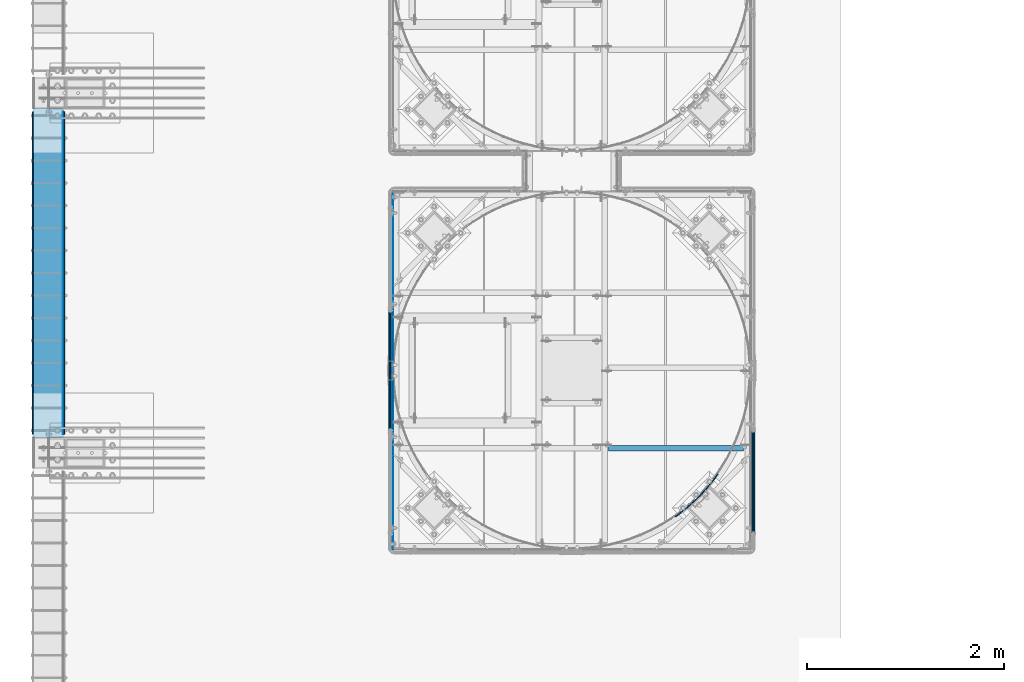
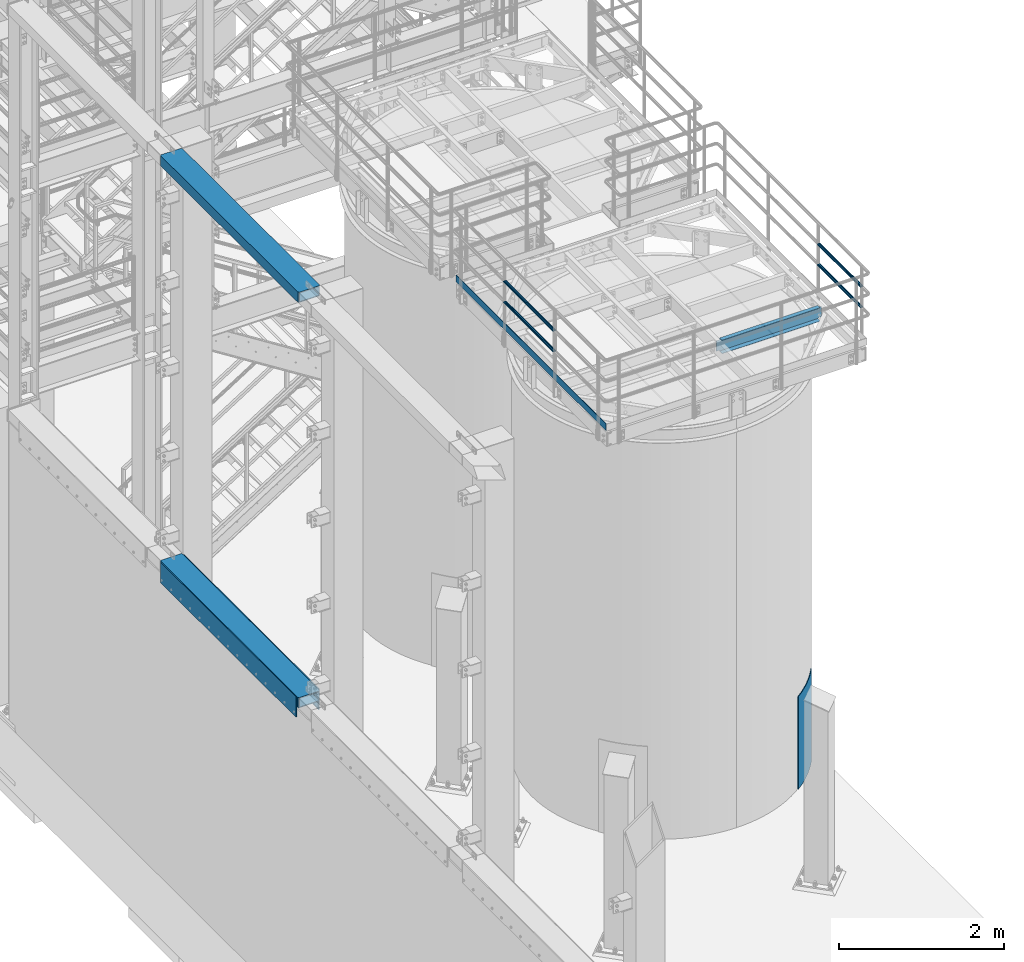
# One storey, part 916 of 1876: 12 beams, 7 elements without a shape of their own.
"""IFC2X3 building model written with IfcOpenShell, lengths in millimetres."""

from ifc_helpers import new_model, si_unit, frame, origin_with_axes, place, context, subcontext, project, spatial, faceted_brep, material, type_object, element, aggregate, save


model = new_model("IFC2X3")

# Units and contexts
model_context = context("Model", 3, precision=1e-05, world=origin_with_axes())
body_context = subcontext(model_context, "Body", "Model", "MODEL_VIEW")
ifc_project = project(units=[si_unit("LENGTHUNIT", "METRE", prefix="MILLI"), si_unit("AREAUNIT", "SQUARE_METRE"), si_unit("VOLUMEUNIT", "CUBIC_METRE"), si_unit("MASSUNIT", "GRAM", prefix="KILO"), si_unit("TIMEUNIT", "SECOND"), si_unit("PLANEANGLEUNIT", "RADIAN"), si_unit("SOLIDANGLEUNIT", "STERADIAN"), si_unit("THERMODYNAMICTEMPERATUREUNIT", "DEGREE_CELSIUS"), si_unit("LUMINOUSINTENSITYUNIT", "LUMEN")], contexts=[model_context])

# Site, building, storey
site_placement = place(None, origin_with_axes())
site = spatial("IfcSite", under=ifc_project, at=site_placement, CompositionType="ELEMENT")
building_placement = place(site_placement, origin_with_axes())
building = spatial("IfcBuilding", under=site, at=building_placement, Name="Undefined", CompositionType="ELEMENT")
storey_placement = place(building_placement, origin_with_axes())
storey = spatial("IfcBuildingStorey", under=building, at=storey_placement, Name="Undefined", CompositionType="ELEMENT", Elevation=0.0)

# Assembly, beam
assembly_1_placement = place(storey_placement, origin_with_axes())
assembly_1 = element("IfcElementAssembly", 1, at=assembly_1_placement, inside=storey, Name="BEAM", AssemblyPlace="NOTDEFINED", PredefinedType="RIGID_FRAME")
ifc_material_1 = material()
beam_type_1 = type_object("IfcBeamType", Name="HSS12X6X1/2", PredefinedType="NOTDEFINED")
beam_1_placement = place(assembly_1_placement, frame((-139.7, -14274.8, 10591.8), z_axis=(-1.0, 0.0, 0.0), x_axis=(0.0, 1.0, 0.0)))
beam_1 = element("IfcBeam", 2, at=beam_1_placement, type_object=beam_type_1, material=ifc_material_1, Name="BEAM", ObjectType="HSS12X6X1/2", context=body_context, shape_type="Brep", body=[
    faceted_brep([(0.0, -63.5, -139.7), (0.0, -76.2000000000007, -139.699999999812), (0.0, -76.2000000000007, 139.700000000026), (0.0, -63.5, 139.7), (0.0, 76.2000000000007, 139.700000000026), (0.0, 63.5, 139.7), (12.6999999999734, -76.2000000000007, 152.4), (12.6999999999734, 76.2000000000007, 152.4), (0.0, 76.2000000000007, -139.699999999812), (0.0, 63.5, -139.7), (12.7000000000025, -76.2000000000007, -152.4), (12.7000000000025, 76.2000000000007, -152.4), (3340.1, 76.2000000000007, -152.4), (3340.1, -76.2000000000007, -152.4), (3352.8, -63.5, -139.7), (3352.8, 63.5, -139.7), (3352.8, 76.2000000000007, -139.7), (3352.8, -76.2000000000007, -139.7), (3352.8, -76.2000000000007, 139.7), (3340.1, -76.2000000000007, 152.4), (3340.1, 76.2000000000007, 152.4), (3352.8, 76.2000000000007, 139.7), (3352.8, 63.5, 139.7), (3352.8, -63.5, 139.7)], [[[0, 1, 2, 3]], [[4, 5, 3, 2, 6, 7]], [[8, 9, 5, 4]], [[10, 11, 12, 13]], [[0, 9, 8, 11, 10, 1]], [[9, 0, 14, 15]], [[12, 16, 15, 14, 17, 13]], [[6, 2, 1, 10, 13, 17, 18, 19]], [[7, 6, 19, 20]], [[16, 12, 11, 8, 4, 7, 20, 21]], [[15, 16, 21, 22]], [[5, 9, 15, 22]], [[3, 5, 22, 23]], [[0, 3, 23, 14]], [[17, 14, 23, 18]], [[22, 21, 20, 19, 18, 23]]]),
])
aggregate(assembly_1, [beam_1])

assembly_2_placement = place(storey_placement, origin_with_axes())
assembly_2 = element("IfcElementAssembly", 3, at=assembly_2_placement, inside=storey, Name="BEAM", AssemblyPlace="NOTDEFINED", PredefinedType="RIGID_FRAME")
beam_2_placement = place(assembly_2_placement, frame((-139.7, -14274.8, 4597.4), z_axis=(-1.0, 0.0, 0.0), x_axis=(0.0, 1.0, 0.0)))
beam_2 = element("IfcBeam", 4, at=beam_2_placement, type_object=beam_type_1, material=ifc_material_1, Name="BEAM", ObjectType="HSS12X6X1/2", context=body_context, shape_type="Brep", body=[
    faceted_brep([(0.0, 63.5, -139.7), (0.0, -63.5, -139.7), (3352.8, -63.5, -139.7), (3352.8, 63.5, -139.7), (3340.10010842724, 76.1999999999998, -152.4), (3340.10010842724, -76.1999999999998, -152.4), (12.6998385541701, -76.2000000000007, -152.4), (12.6998385541701, 76.2000000000007, -152.4), (0.0, 76.2000000000007, -139.699999999812), (0.0, -76.2000000000007, -139.699999999812), (0.0, -76.2000000000007, 139.700000000026), (0.0, -63.5, 139.7), (0.0, 63.5, 139.7), (3352.8, 63.5, 139.7), (3352.8, -63.5, 139.7), (3352.8, -76.2000000000007, -139.7), (3352.8, -76.2000000000007, 139.7), (3352.8, 76.2000000000007, 139.7), (3340.1, 76.2000000000007, 152.4), (3340.1, -76.2000000000007, 152.4), (12.6999999999734, -76.2000000000007, 152.4), (3352.8, 76.2000000000007, -139.7), (0.0, 76.2000000000007, 139.700000000026), (12.6999999999734, 76.2000000000007, 152.4)], [[[0, 1, 2, 3]], [[4, 5, 6, 7]], [[1, 0, 8, 7, 6, 9]], [[1, 9, 10, 11]], [[11, 12, 13, 14]], [[1, 11, 14, 2]], [[15, 2, 14, 16]], [[13, 17, 18, 19, 16, 14]], [[9, 6, 5, 15, 16, 19, 20, 10]], [[4, 21, 3, 2, 15, 5]], [[3, 21, 17, 13]], [[12, 0, 3, 13]], [[8, 0, 12, 22]], [[18, 17, 21, 4, 7, 8, 22, 23]], [[23, 20, 19, 18]], [[22, 12, 11, 10, 20, 23]]]),
])

# Assembly, beams
assembly_3_placement = place(storey_placement, origin_with_axes())
assembly_3 = element("IfcElementAssembly", 5, at=assembly_3_placement, inside=storey, Name="PLATE", AssemblyPlace="NOTDEFINED", PredefinedType="RIGID_FRAME")
ifc_material_2 = material(Name="STEEL/A36")
beam_type_2 = type_object("IfcBeamType", PredefinedType="NOTDEFINED")
beam_3_placement = place(assembly_3_placement, frame((8.73150000000262, -10960.1, 4432.3), z_axis=(0.0, 0.0, 1.0), x_axis=(0.0, -1.0, 0.0)))
beam_3 = element("IfcBeam", 6, at=beam_3_placement, type_object=beam_type_2, material=ifc_material_2, Name="PLATE", context=body_context, shape_type="Brep", body=[
    faceted_brep([(0.0, 3.969, -38.1000000000004), (0.0, 3.969, 38.1000000000004), (3276.6, 3.96900000000096, 38.1000000000004), (3276.6, 3.96900000000096, -38.1000000000004), (0.0, -3.969, 38.1000000000004), (3276.6, -3.96900000000096, 38.1000000000004), (0.0, -3.969, -38.1000000000004), (3276.6, -3.96900000000096, -38.1000000000004)], [[[0, 1, 2, 3]], [[1, 4, 5, 2]], [[4, 6, 7, 5]], [[6, 0, 3, 7]], [[5, 7, 3, 2]], [[6, 4, 1, 0]]]),
])
beam_type_3 = type_object("IfcBeamType", PredefinedType="NOTDEFINED")
beam_4_placement = place(assembly_3_placement, frame((19.0500000000011, -10960.1, 4521.2), z_axis=(0.0, 0.0, 1.0), x_axis=(0.0, -1.0, 0.0)))
beam_4 = element("IfcBeam", 7, at=beam_4_placement, type_object=beam_type_3, material=ifc_material_2, Name="PLATE", context=body_context, shape_type="Brep", body=[
    faceted_brep([(0.0, 6.35000000000002, -152.4), (0.0, 6.35000000000002, 152.4), (3276.6, 6.35000000000002, 152.4), (3276.6, 6.35000000000002, -152.4), (0.0, -6.35000000000002, 152.4), (3276.6, -6.35000000000002, 152.4), (0.0, -6.35000000000002, -152.4), (3276.6, -6.35000000000002, -152.4)], [[[0, 1, 2, 3]], [[1, 4, 5, 2]], [[4, 6, 7, 5]], [[6, 0, 3, 7]], [[5, 7, 3, 2]], [[6, 4, 1, 0]]]),
])
aggregate(assembly_3, [beam_3, beam_4])

# Beam
beam_5_placement = place(assembly_2_placement, frame((-298.449999999997, -10960.1, 4521.2), z_axis=(0.0, 0.0, 1.0), x_axis=(0.0, -1.0, 0.0)))
beam_5 = element("IfcBeam", 8, at=beam_5_placement, type_object=beam_type_3, material=ifc_material_2, Name="PLATE", context=body_context, shape_type="Brep", body=[
    faceted_brep([(0.0, 6.35000000000002, -152.4), (0.0, 6.35000000000002, 152.4), (3276.6, 6.35000000000002, 152.4), (3276.6, 6.35000000000002, -152.4), (0.0, -6.35000000000002, 152.4), (3276.6, -6.35000000000002, 152.4), (0.0, -6.35000000000002, -152.4), (3276.6, -6.35000000000002, -152.4)], [[[0, 1, 2, 3]], [[1, 4, 5, 2]], [[4, 6, 7, 5]], [[6, 0, 3, 7]], [[5, 7, 3, 2]], [[6, 4, 1, 0]]]),
])

aggregate(assembly_2, [beam_5, beam_2])

# Assembly, beams
assembly_4_placement = place(storey_placement, origin_with_axes())
assembly_4 = element("IfcElementAssembly", 9, at=assembly_4_placement, inside=storey, Name="HANDRAIL", AssemblyPlace="NOTDEFINED", PredefinedType="RIGID_FRAME")
ifc_material_3 = material()
beam_type_4 = type_object("IfcBeamType", Name="PIPE1-1/4STD", PredefinedType="NOTDEFINED")
beam_6_placement = place(assembly_4_placement, frame((3338.06943150122, -14198.5644042969, 8480.425), z_axis=(0.0, 0.0, 1.0), x_axis=(0.0, 1.0, 0.0)))
beam_6 = element("IfcBeam", 10, at=beam_6_placement, type_object=beam_type_4, material=ifc_material_3, Name="RAIL", ObjectType="PIPE1-1/4STD", context=body_context, shape_type="Brep", body=[
    faceted_brep([(1200.94245243742, -10.5409999999993, 18.2575475625836), (1200.94245243742, -10.5409999999993, 13.3999612267253), (1200.46603877327, -8.76300000000083, 15.1779612267255), (1198.118, 0.0, 17.5259999999998), (1198.118, 0.0, 21.0820000000003), (1200.46603877327, 8.76300000000083, 15.1779612267255), (1200.94245243742, 10.5409999999993, 13.3999612267253), (1200.94245243742, 10.5409999999993, 18.2575475625836), (1219.2, 21.0820000000003, 0.0), (1208.659, 18.2575475625836, 10.5409999999993), (1208.659, 18.2575475625836, -10.5409999999993), (1205.57941366414, 15.1779612267255, 8.76300000000083), (1207.92745243742, 17.5259999999998, 0.0), (1205.57941366414, 15.1779612267255, -8.76300000000083), (1200.94245243742, 10.5409999999993, -13.3999612267253), (1200.94245243742, 10.5409999999993, -18.2575475625836), (1200.46603877327, 8.76300000000083, -15.1779612267255), (1198.118, 0.0, -17.5259999999998), (1198.118, 0.0, -21.0820000000003), (1200.94245243742, -10.5409999999993, -13.3999612267253), (1200.94245243742, -10.5409999999993, -18.2575475625836), (1200.46603877327, -8.76300000000083, -15.1779612267255), (1219.2, -21.0820000000003, 0.0), (1208.659, -18.2575475625836, -10.5409999999993), (1208.659, -18.2575475625836, 10.5409999999993), (1205.57941366414, -15.1779612267255, -8.76300000000083), (1207.92745243742, -17.5259999999998, 0.0), (1205.57941366414, -15.1779612267255, 8.76300000000083), (10.5409999957128, -18.2575475672238, -10.5409999999993), (18.2575475625817, -10.5410000000011, -18.2575475625836), (9.09494701772928e-13, 21.0820000000003, 0.0), (10.5409999957128, 18.2575475579433, -10.5409999999993), (10.5409999999983, 18.2575475625836, 10.5410000000011), (18.2575475625817, 10.5409999999993, 18.2575475625836), (21.0819999999985, 1.81898940354586e-12, 21.0820000000003), (18.2575475625817, 10.5409999999993, -18.2575475625836), (21.0819999999985, 0.0, -21.0819999999985), (21.0819999999985, 0.0, -17.5259999999998), (18.2575475625817, -10.5409999999974, -13.3999612267271), (18.7339612267233, -8.76300000000083, -15.1779612267255), (18.7339612267251, 8.76299999999901, -15.1779612267255), (18.2575475625817, 10.5410000000011, -13.3999612267235), (13.6205863358573, 15.1779612267255, -8.76299999999901), (11.2725475625839, 17.5259999999998, 0.0), (13.6205863358573, 15.1779612267255, 8.76300000000083), (18.2575475625817, 10.5410000000011, 13.3999612267253), (18.7339612267251, 8.76299999999901, 15.1779612267273), (21.0819999999985, 1.81898940354586e-12, 17.5259999999998), (18.7339612267233, -8.76300000000083, 15.1779612267273), (18.2575475625817, -10.5409999999974, 13.3999612267289), (18.2575475625817, -10.5410000000011, 18.2575475625836), (10.5409999999983, -18.2575475625836, 10.5410000000011), (9.09494701772928e-13, -21.0820000000003, 0.0), (13.6205863358537, -15.1779612267255, 8.76300000000083), (11.2725475625793, -17.5259999999998, 0.0), (13.6205863358537, -15.1779612267255, -8.76299999999901)], [[[0, 1, 2, 3, 4]], [[4, 3, 5, 6, 7]], [[8, 9, 10]], [[7, 6, 11, 12, 13, 14, 15, 10, 9]], [[16, 17, 18, 15, 14]], [[19, 20, 18, 17, 21]], [[22, 23, 24]], [[24, 23, 20, 19, 25, 26, 27, 1, 0]], [[28, 29, 20, 23]], [[30, 31, 32]], [[33, 34, 4, 7]], [[32, 33, 7, 9]], [[30, 32, 9, 8]], [[31, 30, 8, 10]], [[35, 31, 10, 15]], [[36, 35, 15, 18]], [[29, 36, 18, 20]], [[37, 36, 29, 38, 39]], [[40, 41, 35, 36, 37]], [[32, 31, 35, 41, 42, 43, 44, 45, 33]], [[33, 45, 46, 47, 34]], [[34, 47, 48, 49, 50]], [[34, 50, 0, 4]], [[50, 51, 24, 0]], [[51, 52, 22, 24]], [[52, 28, 23, 22]], [[51, 28, 52]], [[50, 49, 53, 54, 55, 38, 29, 28, 51]], [[55, 54, 26, 25]], [[21, 39, 38, 55, 25, 19]], [[37, 39, 21, 17]], [[40, 37, 17, 16]], [[42, 41, 40, 16, 14, 13]], [[43, 42, 13, 12]], [[44, 43, 12, 11]], [[5, 46, 45, 44, 11, 6]], [[47, 46, 5, 3]], [[48, 47, 3, 2]], [[53, 49, 48, 2, 1, 27]], [[54, 53, 27, 26]]]),
])
beam_7_placement = place(assembly_4_placement, frame((3338.06943150122, -12979.3644042969, 8785.225), z_axis=(0.0, 0.0, -1.0), x_axis=(0.0, -1.0, 0.0)))
beam_7 = element("IfcBeam", 11, at=beam_7_placement, type_object=beam_type_4, material=ifc_material_3, Name="RAIL", ObjectType="PIPE1-1/4STD", context=body_context, shape_type="Brep", body=[
    faceted_brep([(9.09494701772928e-13, 21.0820000000003, 0.0), (10.5409999957128, 18.2575475579433, -10.5409999999993), (10.5409999999983, 18.2575475625836, 10.5410000000011), (10.5409999999983, -18.2575475625836, 10.5410000000011), (10.5409999957128, -18.2575475672238, -10.5409999999993), (9.09494701772928e-13, -21.0820000000003, 0.0), (18.2575475625817, -10.5410000000011, 18.2575475625836), (18.2575475625817, -10.5409999999974, 13.3999612267289), (13.6205863358537, -15.1779612267255, 8.76300000000083), (11.2725475625793, -17.5259999999998, 0.0), (13.6205863358537, -15.1779612267255, -8.76299999999901), (18.2575475625817, -10.5409999999974, -13.3999612267271), (18.2575475625817, -10.5410000000011, -18.2575475625836), (21.0819999999985, 0.0, -17.5259999999998), (21.0819999999985, 0.0, -21.0819999999985), (18.7339612267233, -8.76300000000083, -15.1779612267255), (18.7339612267251, 8.76299999999901, -15.1779612267255), (18.2575475625817, 10.5410000000011, -13.3999612267235), (18.2575475625817, 10.5409999999993, -18.2575475625836), (13.6205863358573, 15.1779612267255, -8.76299999999901), (11.2725475625839, 17.5259999999998, 0.0), (13.6205863358573, 15.1779612267255, 8.76300000000083), (18.2575475625817, 10.5410000000011, 13.3999612267253), (18.2575475625817, 10.5409999999993, 18.2575475625836), (18.7339612267251, 8.76299999999901, 15.1779612267273), (21.0819999999985, 1.81898940354586e-12, 17.5259999999998), (21.0819999999985, 1.81898940354586e-12, 21.0820000000003), (18.7339612267233, -8.76300000000083, 15.1779612267273), (1219.2, 21.0820000000003, 0.0), (1208.659, 18.2575475625836, -10.5409999999993), (1200.94245243742, 10.5409999999993, -18.2575475625836), (1219.2, -21.0820000000003, 0.0), (1208.659, -18.2575475625836, -10.5409999999993), (1208.659, -18.2575475625836, 10.5409999999993), (1200.94245243742, -10.5409999999993, 18.2575475625836), (1200.94245243742, -10.5409999999993, -18.2575475625836), (1198.118, 0.0, -21.0820000000003), (1200.46603877327, 8.76300000000083, -15.1779612267255), (1198.118, 0.0, -17.5259999999998), (1200.94245243742, 10.5409999999993, -13.3999612267253), (1200.94245243742, -10.5409999999993, -13.3999612267253), (1200.46603877327, -8.76300000000083, -15.1779612267255), (1205.57941366414, -15.1779612267255, -8.76300000000083), (1207.92745243742, -17.5259999999998, 0.0), (1205.57941366414, -15.1779612267255, 8.76300000000083), (1200.94245243742, -10.5409999999993, 13.3999612267253), (1200.46603877327, -8.76300000000083, 15.1779612267255), (1198.118, 0.0, 17.5259999999998), (1198.118, 0.0, 21.0820000000003), (1200.94245243742, 10.5409999999993, 18.2575475625836), (1208.659, 18.2575475625836, 10.5409999999993), (1200.94245243742, 10.5409999999993, 13.3999612267253), (1205.57941366414, 15.1779612267255, 8.76300000000083), (1207.92745243742, 17.5259999999998, 0.0), (1205.57941366414, 15.1779612267255, -8.76300000000083), (1200.46603877327, 8.76300000000083, 15.1779612267255)], [[[0, 1, 2]], [[3, 4, 5]], [[6, 7, 8, 9, 10, 11, 12, 4, 3]], [[13, 14, 12, 11, 15]], [[16, 17, 18, 14, 13]], [[2, 1, 18, 17, 19, 20, 21, 22, 23]], [[23, 22, 24, 25, 26]], [[26, 25, 27, 7, 6]], [[1, 0, 28, 29]], [[18, 1, 29, 30]], [[31, 32, 33]], [[6, 3, 33, 34]], [[3, 5, 31, 33]], [[5, 4, 32, 31]], [[4, 12, 35, 32]], [[12, 14, 36, 35]], [[14, 18, 30, 36]], [[37, 38, 36, 30, 39]], [[40, 35, 36, 38, 41]], [[33, 32, 35, 40, 42, 43, 44, 45, 34]], [[34, 45, 46, 47, 48]], [[26, 6, 34, 48]], [[2, 23, 49, 50]], [[23, 26, 48, 49]], [[0, 2, 50, 28]], [[28, 50, 29]], [[49, 51, 52, 53, 54, 39, 30, 29, 50]], [[48, 47, 55, 51, 49]], [[25, 24, 55, 47]], [[55, 24, 22, 21, 52, 51]], [[21, 20, 53, 52]], [[20, 19, 54, 53]], [[19, 17, 16, 37, 39, 54]], [[16, 13, 38, 37]], [[13, 15, 41, 38]], [[41, 15, 11, 10, 42, 40]], [[10, 9, 43, 42]], [[9, 8, 44, 43]], [[8, 7, 27, 46, 45, 44]], [[27, 25, 47, 46]]]),
])

assembly_5_placement = place(storey_placement, origin_with_axes())
assembly_5 = element("IfcElementAssembly", 12, at=assembly_5_placement, inside=storey, Name="HANDRAIL", AssemblyPlace="NOTDEFINED", PredefinedType="RIGID_FRAME")
beam_8_placement = place(assembly_5_placement, frame((7025.13056849878, -15252.6644042969, 8480.425), z_axis=(0.0, 0.0, 1.0), x_axis=(0.0, 1.0, 0.0)))
beam_8 = element("IfcBeam", 13, at=beam_8_placement, type_object=beam_type_4, material=ifc_material_3, Name="RAIL", ObjectType="PIPE1-1/4STD", context=body_context, shape_type="Brep", body=[
    faceted_brep([(1035.84245243742, -10.5409999999993, 18.2575475625836), (1035.84245243742, -10.5409999999993, 13.3999612267253), (1035.36603877327, -8.76300000000083, 15.1779612267255), (1033.018, 0.0, 17.5259999999998), (1033.018, 0.0, 21.0820000000003), (1035.36603877327, 8.76300000000083, 15.1779612267255), (1035.84245243742, 10.5409999999993, 13.3999612267253), (1035.84245243742, 10.5409999999993, 18.2575475625836), (1054.1, 21.0820000000003, 0.0), (1043.559, 18.2575475625836, 10.5409999999993), (1043.559, 18.2575475625836, -10.5409999999993), (1040.47941366414, 15.1779612267255, 8.76300000000083), (1042.82745243742, 17.5259999999998, 0.0), (1040.47941366414, 15.1779612267255, -8.76300000000083), (1035.84245243742, 10.5409999999993, -13.3999612267253), (1035.84245243742, 10.5409999999993, -18.2575475625836), (1035.36603877327, 8.76300000000083, -15.1779612267255), (1033.018, 0.0, -17.5259999999998), (1033.018, 0.0, -21.0820000000003), (1035.84245243742, -10.5409999999993, -13.3999612267253), (1035.84245243742, -10.5409999999993, -18.2575475625836), (1035.36603877327, -8.76300000000083, -15.1779612267255), (1054.1, -21.0820000000003, 0.0), (1043.559, -18.2575475625836, -10.5409999999993), (1043.559, -18.2575475625836, 10.5409999999993), (1040.47941366414, -15.1779612267255, -8.76300000000083), (1042.82745243742, -17.5259999999998, 0.0), (1040.47941366414, -15.1779612267255, 8.76300000000083), (10.5409999957128, -18.2575475672238, -10.5409999999993), (18.2575475625817, -10.5410000000011, -18.2575475625836), (9.09494701772928e-13, 21.0820000000003, 0.0), (10.5409999957128, 18.2575475579433, -10.5409999999993), (10.5409999999983, 18.2575475625836, 10.5410000000011), (18.2575475625817, 10.5409999999993, 18.2575475625836), (21.0819999999985, 1.81898940354586e-12, 21.0820000000003), (18.2575475625817, 10.5409999999993, -18.2575475625836), (21.0819999999985, 0.0, -21.0819999999985), (21.0819999999985, 0.0, -17.5259999999998), (18.2575475625817, -10.5409999999974, -13.3999612267271), (18.7339612267233, -8.76300000000083, -15.1779612267255), (18.7339612267251, 8.76299999999901, -15.1779612267255), (18.2575475625817, 10.5410000000011, -13.3999612267235), (13.6205863358573, 15.1779612267255, -8.76299999999901), (11.2725475625839, 17.5259999999998, 0.0), (13.6205863358573, 15.1779612267255, 8.76300000000083), (18.2575475625817, 10.5410000000011, 13.3999612267253), (18.7339612267251, 8.76299999999901, 15.1779612267273), (21.0819999999985, 1.81898940354586e-12, 17.5259999999998), (18.7339612267233, -8.76300000000083, 15.1779612267273), (18.2575475625817, -10.5409999999974, 13.3999612267289), (18.2575475625817, -10.5410000000011, 18.2575475625836), (10.5409999999983, -18.2575475625836, 10.5410000000011), (9.09494701772928e-13, -21.0820000000003, 0.0), (13.6205863358537, -15.1779612267255, 8.76300000000083), (11.2725475625793, -17.5259999999998, 0.0), (13.6205863358537, -15.1779612267255, -8.76299999999901)], [[[0, 1, 2, 3, 4]], [[4, 3, 5, 6, 7]], [[8, 9, 10]], [[7, 6, 11, 12, 13, 14, 15, 10, 9]], [[16, 17, 18, 15, 14]], [[19, 20, 18, 17, 21]], [[22, 23, 24]], [[24, 23, 20, 19, 25, 26, 27, 1, 0]], [[28, 29, 20, 23]], [[30, 31, 32]], [[33, 34, 4, 7]], [[32, 33, 7, 9]], [[30, 32, 9, 8]], [[31, 30, 8, 10]], [[35, 31, 10, 15]], [[36, 35, 15, 18]], [[29, 36, 18, 20]], [[37, 36, 29, 38, 39]], [[40, 41, 35, 36, 37]], [[32, 31, 35, 41, 42, 43, 44, 45, 33]], [[33, 45, 46, 47, 34]], [[34, 47, 48, 49, 50]], [[34, 50, 0, 4]], [[50, 51, 24, 0]], [[51, 52, 22, 24]], [[52, 28, 23, 22]], [[51, 28, 52]], [[50, 49, 53, 54, 55, 38, 29, 28, 51]], [[55, 54, 26, 25]], [[21, 39, 38, 55, 25, 19]], [[37, 39, 21, 17]], [[40, 37, 17, 16]], [[42, 41, 40, 16, 14, 13]], [[43, 42, 13, 12]], [[44, 43, 12, 11]], [[5, 46, 45, 44, 11, 6]], [[47, 46, 5, 3]], [[48, 47, 3, 2]], [[53, 49, 48, 2, 1, 27]], [[54, 53, 27, 26]]]),
])
beam_9_placement = place(assembly_5_placement, frame((7025.13056849878, -14198.5644042969, 8785.225), z_axis=(0.0, 0.0, -1.0), x_axis=(0.0, -1.0, 0.0)))
beam_9 = element("IfcBeam", 14, at=beam_9_placement, type_object=beam_type_4, material=ifc_material_3, Name="RAIL", ObjectType="PIPE1-1/4STD", context=body_context, shape_type="Brep", body=[
    faceted_brep([(9.09494701772928e-13, 21.0820000000003, 0.0), (10.5409999957128, 18.2575475579433, -10.5409999999993), (10.5409999999983, 18.2575475625836, 10.5410000000011), (10.5409999999983, -18.2575475625836, 10.5410000000011), (10.5409999957128, -18.2575475672238, -10.5409999999993), (9.09494701772928e-13, -21.0820000000003, 0.0), (18.2575475625817, -10.5410000000011, 18.2575475625836), (18.2575475625817, -10.5409999999974, 13.3999612267289), (13.6205863358537, -15.1779612267255, 8.76300000000083), (11.2725475625793, -17.5259999999998, 0.0), (13.6205863358537, -15.1779612267255, -8.76299999999901), (18.2575475625817, -10.5409999999974, -13.3999612267271), (18.2575475625817, -10.5410000000011, -18.2575475625836), (21.0819999999985, 0.0, -17.5259999999998), (21.0819999999985, 0.0, -21.0819999999985), (18.7339612267233, -8.76300000000083, -15.1779612267255), (18.7339612267251, 8.76299999999901, -15.1779612267255), (18.2575475625817, 10.5410000000011, -13.3999612267235), (18.2575475625817, 10.5409999999993, -18.2575475625836), (13.6205863358573, 15.1779612267255, -8.76299999999901), (11.2725475625839, 17.5259999999998, 0.0), (13.6205863358573, 15.1779612267255, 8.76300000000083), (18.2575475625817, 10.5410000000011, 13.3999612267253), (18.2575475625817, 10.5409999999993, 18.2575475625836), (18.7339612267251, 8.76299999999901, 15.1779612267273), (21.0819999999985, 1.81898940354586e-12, 17.5259999999998), (21.0819999999985, 1.81898940354586e-12, 21.0820000000003), (18.7339612267233, -8.76300000000083, 15.1779612267273), (1054.1, 21.0820000000003, 0.0), (1043.559, 18.2575475625836, -10.5409999999993), (1035.84245243742, 10.5409999999993, -18.2575475625836), (1054.1, -21.0820000000003, 0.0), (1043.559, -18.2575475625836, -10.5409999999993), (1043.559, -18.2575475625836, 10.5409999999993), (1035.84245243742, -10.5409999999993, 18.2575475625836), (1035.84245243742, -10.5409999999993, -18.2575475625836), (1033.018, 0.0, -21.0820000000003), (1035.36603877327, 8.76300000000083, -15.1779612267255), (1033.018, 0.0, -17.5259999999998), (1035.84245243742, 10.5409999999993, -13.3999612267253), (1035.84245243742, -10.5409999999993, -13.3999612267253), (1035.36603877327, -8.76300000000083, -15.1779612267255), (1040.47941366414, -15.1779612267255, -8.76300000000083), (1042.82745243742, -17.5259999999998, 0.0), (1040.47941366414, -15.1779612267255, 8.76300000000083), (1035.84245243742, -10.5409999999993, 13.3999612267253), (1035.36603877327, -8.76300000000083, 15.1779612267255), (1033.018, 0.0, 17.5259999999998), (1033.018, 0.0, 21.0820000000003), (1035.84245243742, 10.5409999999993, 18.2575475625836), (1043.559, 18.2575475625836, 10.5409999999993), (1035.84245243742, 10.5409999999993, 13.3999612267253), (1040.47941366414, 15.1779612267255, 8.76300000000083), (1042.82745243742, 17.5259999999998, 0.0), (1040.47941366414, 15.1779612267255, -8.76300000000083), (1035.36603877327, 8.76300000000083, 15.1779612267255)], [[[0, 1, 2]], [[3, 4, 5]], [[6, 7, 8, 9, 10, 11, 12, 4, 3]], [[13, 14, 12, 11, 15]], [[16, 17, 18, 14, 13]], [[2, 1, 18, 17, 19, 20, 21, 22, 23]], [[23, 22, 24, 25, 26]], [[26, 25, 27, 7, 6]], [[1, 0, 28, 29]], [[18, 1, 29, 30]], [[31, 32, 33]], [[6, 3, 33, 34]], [[3, 5, 31, 33]], [[5, 4, 32, 31]], [[4, 12, 35, 32]], [[12, 14, 36, 35]], [[14, 18, 30, 36]], [[37, 38, 36, 30, 39]], [[40, 35, 36, 38, 41]], [[33, 32, 35, 40, 42, 43, 44, 45, 34]], [[34, 45, 46, 47, 48]], [[26, 6, 34, 48]], [[2, 23, 49, 50]], [[23, 26, 48, 49]], [[0, 2, 50, 28]], [[28, 50, 29]], [[49, 51, 52, 53, 54, 39, 30, 29, 50]], [[48, 47, 55, 51, 49]], [[25, 24, 55, 47]], [[55, 24, 22, 21, 52, 51]], [[21, 20, 53, 52]], [[20, 19, 54, 53]], [[19, 17, 16, 37, 39, 54]], [[16, 13, 38, 37]], [[13, 15, 41, 38]], [[41, 15, 11, 10, 42, 40]], [[10, 9, 43, 42]], [[9, 8, 44, 43]], [[8, 7, 27, 46, 45, 44]], [[27, 25, 47, 46]]]),
])
aggregate(assembly_5, [beam_8, beam_9])

# Beam
beam_type_5 = type_object("IfcBeamType", PredefinedType="NOTDEFINED")
beam_10_placement = place(assembly_4_placement, frame((3362.326, -15405.0648085937, 8080.375), z_axis=(0.0, 0.0, 1.0), x_axis=(0.0, 1.0, 0.0)))
beam_10 = element("IfcBeam", 15, at=beam_10_placement, type_object=beam_type_5, material=ifc_material_2, Name="PLATE", context=body_context, shape_type="Brep", body=[
    faceted_brep([(0.0, 3.17500000000018, -50.8000000000002), (0.0, 3.17500000000018, 50.8000000000002), (3632.1999511731, 3.17500000000018, 50.8000000000002), (3632.1999511731, 3.17500000000018, -50.8000000000002), (0.0, -3.17500000000018, 50.8000000000002), (3632.1999511731, -3.17500000000018, 50.8000000000002), (0.0, -3.17500000000018, -50.8000000000002), (3632.1999511731, -3.17500000000018, -50.8000000000002)], [[[0, 1, 2, 3]], [[1, 4, 5, 2]], [[4, 6, 7, 5]], [[6, 0, 3, 7]], [[5, 7, 3, 2]], [[6, 4, 1, 0]]]),
])

aggregate(assembly_4, [beam_10, beam_6, beam_7])

# Assembly, beam
assembly_6_placement = place(storey_placement, origin_with_axes())
assembly_6 = element("IfcElementAssembly", 16, at=assembly_6_placement, inside=storey, Name="BEAM", AssemblyPlace="NOTDEFINED", PredefinedType="RIGID_FRAME")
beam_type_6 = type_object("IfcBeamType", Name="C8X11.5", PredefinedType="NOTDEFINED")
beam_11_placement = place(assembly_6_placement, frame((5486.40143150122, -14379.5394042969, 7896.225), z_axis=(0.0, 0.0, 1.0), x_axis=(1.0, 0.0, 0.0)))
beam_11 = element("IfcBeam", 17, at=beam_11_placement, type_object=beam_type_6, material=ifc_material_2, Name="BEAM", ObjectType="C8X11.5", context=body_context, shape_type="Brep", body=[
    faceted_brep([(1441.44713699756, -28.5750000000007, -96.8355949999996), (1441.44713699756, -28.5750000000007, -101.6), (1441.44713699756, 28.5750000000007, -101.6), (1441.44713699756, 28.5750000000007, -88.899999809264), (1441.44713699756, 19.0576241940926, -88.899999809264), (1441.5521000322, 22.2250000000004, -88.3723149999996), (1442.41386692015, 28.5750000000007, -84.0399202912186), (1442.41386692015, 22.2250000000004, -84.0399202912186), (1445.16688082063, 28.5750000000007, -79.9197438230649), (1445.16688082063, 22.2250000000004, -79.9197438230649), (1449.28705728878, 28.5750000000007, -77.1667299225865), (1449.28705728878, 22.2250000000004, -77.1667299225865), (1454.14713680683, 28.5750000000007, -76.1999999999989), (1454.14713680683, 22.2250000000004, -76.1999999999989), (1492.24713699756, 22.2250000000004, -76.1999999999989), (1492.24713699756, 28.5750000000007, -76.1999999999989), (1441.44713699756, -28.5750000000007, 101.6), (1441.44713699756, 28.5750000000007, 101.6), (69.8500000000013, 28.5750000000007, 101.6), (69.8500000000013, -28.5750000000007, 101.6), (69.8500000000013, 19.0576241940817, -88.8999998092659), (69.8500000000013, 28.5750000000007, -88.8999998092659), (69.8500000000013, 28.5750000000007, -101.6), (69.8500000000013, -28.5750000000007, -101.6), (69.8500000000013, -28.5750000000007, -96.8355949999996), (69.7450369653598, 22.2250000000004, -88.3723149999996), (68.8832700774137, 22.2250000000004, -84.0399202912204), (68.8832700774137, 28.5750000000007, -84.0399202912204), (66.1302561769353, 22.2250000000004, -79.9197438230667), (66.1302561769353, 28.5750000000007, -79.9197438230667), (62.0100797087816, 22.2250000000004, -77.1667299225883), (62.0100797087816, 28.5750000000007, -77.1667299225883), (57.1500001907361, 22.2250000000004, -76.2000000000007), (57.1500001907361, 28.5750000000007, -76.2000000000007), (19.0499999999993, 22.2250000000004, -76.2000000000007), (19.0499999999993, 28.5750000000007, -76.2000000000007), (19.0499999999993, 22.2250000000004, 76.1999999999989), (19.0499999999993, 28.5750000000007, 76.1999999999989), (57.1500001907361, 22.2250000000004, 76.1999999999989), (57.1500001907361, 28.5750000000007, 76.1999999999989), (62.0100797087816, 22.2250000000004, 77.1667299225865), (62.0100797087816, 28.5750000000007, 77.1667299225865), (66.1302561769353, 22.2250000000004, 79.9197438230649), (66.1302561769353, 28.5750000000007, 79.9197438230649), (68.8832700774137, 22.2250000000004, 84.0399202912186), (68.8832700774137, 28.5750000000007, 84.0399202912186), (69.8500000000013, 19.0576241940926, 88.899999809264), (69.8500000000013, 28.5750000000007, 88.899999809264), (69.7450369653607, 22.2250000000004, 88.3723149999996), (69.8500000000013, -28.5750000000007, 96.8355949999996), (1441.44713699756, -28.5750000000007, 96.8355949999996), (1441.44713699756, 19.0576241940817, 88.8999998092659), (1441.44713699756, 28.5750000000007, 88.8999998092659), (1441.5521000322, 22.2250000000004, 88.3723149999996), (1442.41386692015, 22.2250000000004, 84.0399202912204), (1442.41386692015, 28.5750000000007, 84.0399202912204), (1445.16688082063, 22.2250000000004, 79.9197438230667), (1445.16688082063, 28.5750000000007, 79.9197438230667), (1449.28705728878, 22.2250000000004, 77.1667299225883), (1449.28705728878, 28.5750000000007, 77.1667299225883), (1454.14713680683, 22.2250000000004, 76.2000000000007), (1454.14713680683, 28.5750000000007, 76.2000000000007), (1492.24713699756, 22.2250000000004, 76.2000000000007), (1492.24713699756, 28.5750000000007, 76.2000000000007)], [[[0, 1, 2, 3, 4]], [[5, 4, 3, 6, 7]], [[7, 6, 8, 9]], [[9, 8, 10, 11]], [[11, 10, 12, 13]], [[14, 13, 12, 15]], [[16, 17, 18, 19]], [[20, 21, 22, 23, 24]], [[25, 26, 27, 21, 20]], [[28, 29, 27, 26]], [[30, 31, 29, 28]], [[32, 33, 31, 30]], [[34, 35, 33, 32]], [[36, 37, 35, 34]], [[38, 39, 37, 36]], [[40, 41, 39, 38]], [[42, 43, 41, 40]], [[44, 45, 43, 42]], [[46, 47, 45, 44, 48]], [[19, 18, 47, 46, 49]], [[50, 16, 19, 49]], [[16, 50, 51, 52, 17]], [[48, 53, 51, 50, 49, 46]], [[54, 55, 52, 51, 53]], [[56, 57, 55, 54]], [[58, 59, 57, 56]], [[60, 61, 59, 58]], [[62, 63, 61, 60]], [[63, 62, 14, 15]], [[29, 31, 33, 35, 37, 39, 41, 43, 45, 47, 18, 17, 52, 55, 57, 59, 61, 63, 15, 12, 10, 8, 6, 3, 2, 22, 21, 27]], [[2, 1, 23, 22]], [[1, 0, 24, 23]], [[24, 0, 4, 5, 25, 20]], [[5, 7, 9, 11, 13, 14, 62, 60, 58, 56, 54, 53, 48, 44, 42, 40, 38, 36, 34, 32, 30, 28, 26, 25]]]),
])
aggregate(assembly_6, [beam_11])

assembly_7_placement = place(storey_placement, origin_with_axes())
assembly_7 = element("IfcElementAssembly", 18, at=assembly_7_placement, inside=storey, Name="COLUMN", AssemblyPlace="NOTDEFINED", PredefinedType="RIGID_FRAME")
beam_type_7 = type_object("IfcBeamType", PredefinedType="NOTDEFINED")
beam_12_placement = place(assembly_7_placement, frame((6234.7895206541, -15074.3721979111, 2209.8), z_axis=(0.0, 0.0, 1.0), x_axis=(0.707106781186548, 0.707106781186547, 0.0)))
beam_12 = element("IfcBeam", 19, at=beam_12_placement, type_object=beam_type_7, material=ifc_material_2, Name="PLATE", context=body_context, shape_type="Brep", body=[
    faceted_brep([(0.79930179960138, 4.69494652612411, -685.8), (0.79930179960138, 4.69494652612411, 685.8), (61.342263906226, -4.5647055990521, 685.8), (61.342263906226, -4.5647055990521, -685.8), (-0.799301799600926, -4.69494652612411, 685.8), (-0.799301799600926, -4.69494652612411, -685.8), (60.0611937621738, -14.003163327201, -685.8), (60.0611937621738, -14.003163327201, 685.8), (122.16302969072, -11.7776015161726, 685.8), (122.16302969072, -11.7776015161726, -685.8), (121.200950016122, -21.2538891700879, -685.8), (121.200950016122, -21.2538891700879, 685.8), (183.192425169105, -16.9355376990206, 685.8), (183.192425169105, -16.9355376990206, -685.8), (182.550430177147, -26.438877503022, -685.8), (182.550430177147, -26.438877503022, 685.8), (244.361039074185, -20.0326478124662, 685.8), (244.361039074185, -20.0326478124662, -685.8), (244.039858932445, -29.5522312233406, -685.8), (244.039858932445, -29.5522312233406, 685.8), (305.59930179986, -21.0654093844969, 685.8), (305.59930179986, -21.0654093844969, -685.8), (305.599301799861, -30.5904093844983, -685.8), (305.599301799861, -30.5904093844983, 685.8), (366.837564525536, -20.0326478124662, 685.8), (366.837564525536, -20.0326478124662, -685.8), (367.158744667275, -29.5522312233406, -685.8), (367.158744667275, -29.5522312233406, 685.8), (428.006178430616, -16.9355376990206, 685.8), (428.006178430616, -16.9355376990206, -685.8), (428.648173422574, -26.438877503022, -685.8), (428.648173422574, -26.438877503022, 685.8), (489.035573909001, -11.7776015161708, 685.8), (489.035573909001, -11.7776015161708, -685.8), (489.997653583599, -21.253889170086, -685.8), (489.997653583599, -21.253889170086, 685.8), (549.856339693495, -4.5647055990521, 685.8), (549.856339693495, -4.5647055990521, -685.8), (551.137409837547, -14.003163327201, -685.8), (551.137409837547, -14.003163327201, 685.8), (610.39930180012, 4.69494652612411, 685.8), (610.39930180012, 4.69494652612411, -685.8), (611.997905399323, -4.69494652612229, 685.8), (611.997905399323, -4.69494652612229, -685.8)], [[[0, 1, 2, 3]], [[4, 5, 6, 7]], [[5, 4, 1, 0]], [[3, 2, 8, 9]], [[7, 6, 10, 11]], [[9, 8, 12, 13]], [[11, 10, 14, 15]], [[13, 12, 16, 17]], [[15, 14, 18, 19]], [[17, 16, 20, 21]], [[19, 18, 22, 23]], [[21, 20, 24, 25]], [[23, 22, 26, 27]], [[25, 24, 28, 29]], [[27, 26, 30, 31]], [[29, 28, 32, 33]], [[31, 30, 34, 35]], [[33, 32, 36, 37]], [[35, 34, 38, 39]], [[37, 36, 40, 41]], [[36, 32, 28, 24, 20, 16, 12, 8, 2, 1, 4, 7, 11, 15, 19, 23, 27, 31, 35, 39, 42, 40]], [[39, 38, 43, 42]], [[38, 34, 30, 26, 22, 18, 14, 10, 6, 5, 0, 3, 9, 13, 17, 21, 25, 29, 33, 37, 41, 43]], [[42, 43, 41, 40]]]),
])
aggregate(assembly_7, [beam_12])

save(model, "model.ifc")
